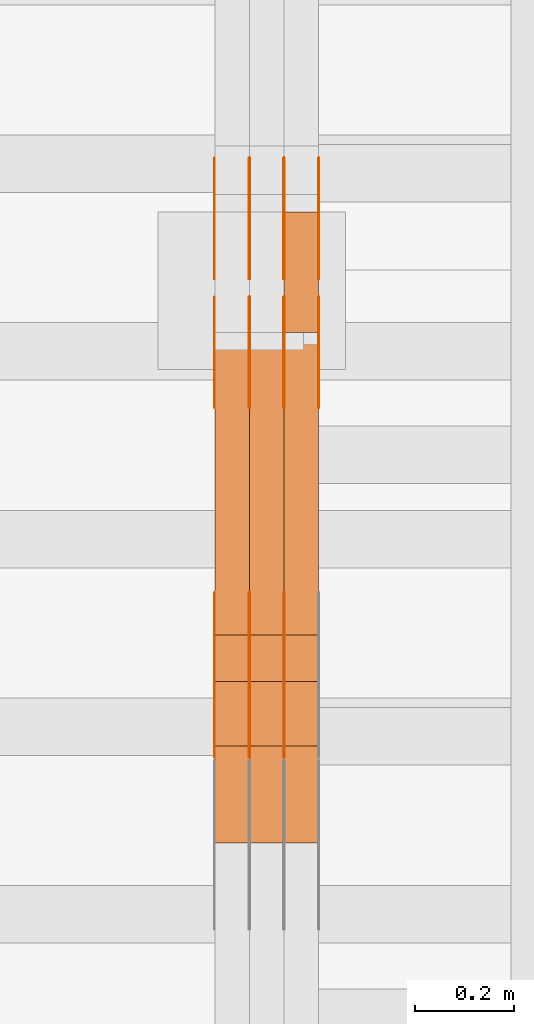
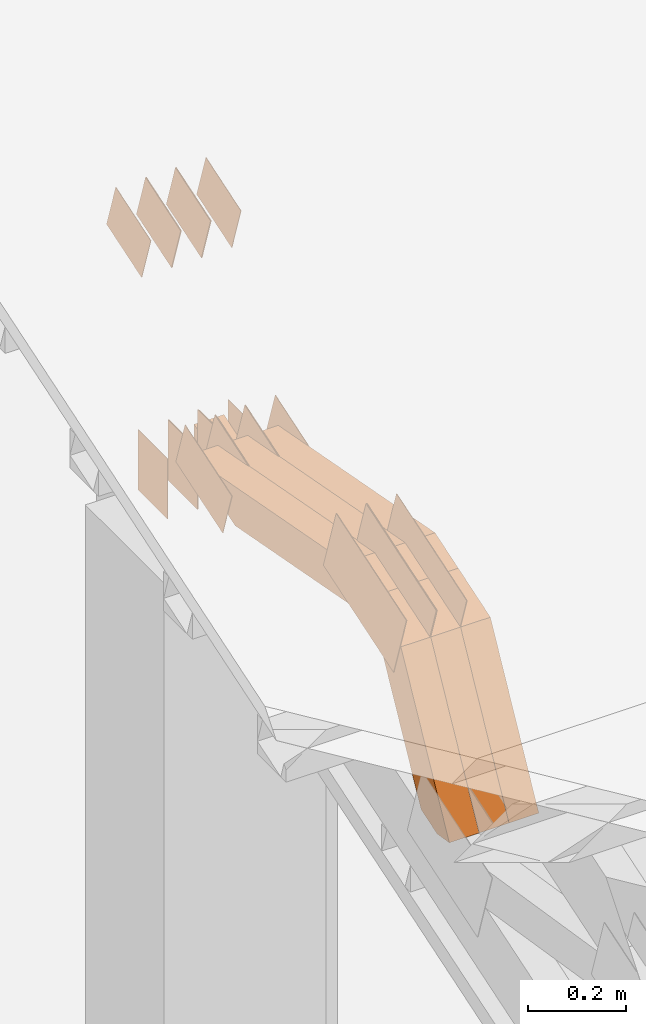
# One storey, part 74 of 385: 29 proxies.
"""IFC2X3 building model written with IfcOpenShell, lengths in millimetres."""

import ifcopenshell
import ifcopenshell.guid

model = None  # the IFC model being written
_history = None  # IfcOwnerHistory: only IFC2X3 demands one
_inside = {}  # id of a spatial element -> (the spatial element, [elements in it])
_under = {}  # id of a project, library or spatial element -> (it, [spatial elements below it])
_declared = {}  # id of a project -> (the project, [libraries it declares])
_typed = {}  # id of a type object -> (the type object, [elements of that type])
_made_of = {}  # id of a material, layer set ... -> (it, [elements and type objects made of it])


def new_model(schema):
    """Start an empty IFC model of exactly this schema.

    Asked for "IFC4X3", IfcOpenShell would pick the latest addendum, in which some entities
    have other attributes; the version numbers below select the first issue.
    IFC2X3 requires an IfcOwnerHistory on every rooted entity: one is made here for all.
    """
    global model, _history
    if schema == "IFC4X3":
        model = ifcopenshell.file(schema_version=(4, 3, 0, 0))
    else:
        model = ifcopenshell.file(schema=schema)
    _inside.clear()
    _under.clear()
    _declared.clear()
    _typed.clear()
    _made_of.clear()
    _history = None
    if model.schema == "IFC2X3":
        org = make("IfcOrganization", Name="unknown")
        user = make(
            "IfcPersonAndOrganization",
            ThePerson=make("IfcPerson", FamilyName="unknown"),
            TheOrganization=org,
        )
        app = make(
            "IfcApplication",
            ApplicationDeveloper=org,
            Version="unknown",
            ApplicationFullName="unknown",
            ApplicationIdentifier="unknown",
        )
        _history = make(
            "IfcOwnerHistory",
            OwningUser=user,
            OwningApplication=app,
            ChangeAction="ADDED",
            CreationDate=0,
        )
    return model


def make(cls, **values):
    """One entity of the class cls with the attributes given. An attribute that is None is left unset."""
    return model.create_entity(
        cls, **{name: value for name, value in values.items() if value is not None}
    )


def entity(cls, *values):
    """Any entity or typed value of the class cls, its attributes in the order of the schema. None: left unset."""
    e = model.create_entity(cls)
    for i, value in enumerate(values):
        if value is not None:
            e[i] = value
    return e


def rooted(cls, **values):
    """An entity with a GlobalId (a new one), such as an element, a storey or a relation."""
    return make(cls, GlobalId=ifcopenshell.guid.new(), OwnerHistory=_history, **values)


def si_unit(unit_type, name, prefix=None):
    """IfcSIUnit, for example si_unit("LENGTHUNIT", "METRE", prefix="MILLI")."""
    return make("IfcSIUnit", UnitType=unit_type, Prefix=prefix, Name=name)


def converted_unit(unit_type, name, factor, base, dimensions=None, offset=None):
    """IfcConversionBasedUnit, such as the inch: factor (a typed value) times the base unit."""
    return make(
        "IfcConversionBasedUnit"
        if offset is None
        else "IfcConversionBasedUnitWithOffset",
        ConversionOffset=offset,
        Dimensions=None
        if dimensions is None
        else entity("IfcDimensionalExponents", *dimensions),
        UnitType=unit_type,
        Name=name,
        ConversionFactor=make(
            "IfcMeasureWithUnit", ValueComponent=factor, UnitComponent=base
        ),
    )


def derived_unit(unit_type, elements):
    """IfcDerivedUnit: a product of units, each with its exponent."""
    return make(
        "IfcDerivedUnit",
        Elements=[
            make("IfcDerivedUnitElement", Unit=unit, Exponent=power)
            for unit, power in elements
        ],
        UnitType=unit_type,
    )


def assignment(units):
    """IfcUnitAssignment: the units of a project."""
    return None if units is None else make("IfcUnitAssignment", Units=units)


def point(xyz):
    """IfcCartesianPoint."""
    return None if xyz is None else make("IfcCartesianPoint", Coordinates=xyz)


def direction(xyz):
    """IfcDirection."""
    return None if xyz is None else make("IfcDirection", DirectionRatios=xyz)


def frame(location, z_axis=None, x_axis=None):
    """IfcAxis2Placement3D, a coordinate frame: its origin and axes. An axis left out is left unset."""
    return make(
        "IfcAxis2Placement3D",
        Location=point(location),
        Axis=direction(z_axis),
        RefDirection=direction(x_axis),
    )


def frame_2d(location, x_axis=None):
    """IfcAxis2Placement2D, a coordinate frame in the plane: its origin and x axis."""
    return make(
        "IfcAxis2Placement2D", Location=point(location), RefDirection=direction(x_axis)
    )


def origin():
    """The frame at (0, 0, 0) with its axes left unset."""
    return frame((0.0, 0.0, 0.0))


def place(relative_to, where):
    """IfcLocalPlacement: puts the frame where relative to a parent placement (None: the world)."""
    return make(
        "IfcLocalPlacement", PlacementRelTo=relative_to, RelativePlacement=where
    )


def context(
    kind, dimensions, precision=None, world=None, true_north=None, identifier=None
):
    """IfcGeometricRepresentationContext, for example the 3D "Model" context."""
    return make(
        "IfcGeometricRepresentationContext",
        ContextIdentifier=identifier,
        ContextType=kind,
        CoordinateSpaceDimension=dimensions,
        Precision=precision,
        WorldCoordinateSystem=world,
        TrueNorth=true_north,
    )


def subcontext(parent, identifier, kind, view, scale=None):
    """IfcGeometricRepresentationSubContext, for example "Body" below "Model"."""
    return make(
        "IfcGeometricRepresentationSubContext",
        ContextIdentifier=identifier,
        ContextType=kind,
        ParentContext=parent,
        TargetScale=scale,
        TargetView=view,
    )


def project(units=None, contexts=None):
    """IfcProject with its units and contexts."""
    return rooted(
        "IfcProject",
        Name="project",
        RepresentationContexts=contexts,
        UnitsInContext=assignment(units),
    )


def spatial(cls, under=None, at=None, **own):
    """A site, building, storey or space (cls), placed at a placement, below another one or the project."""
    s = rooted(cls, ObjectPlacement=at, **own)
    if under is not None:
        _under.setdefault(under.id(), (under, []))[1].append(s)
    return s


def polyline(points):
    """IfcPolyline through the points."""
    return make("IfcPolyline", Points=[point(p) for p in points])


def profile(cls, at=None, kind="AREA", **sizes):
    """A parametric profile (cls). Its sizes go by their IFC names, for example OverallWidth=200.0."""
    return make(cls, ProfileType=kind, Position=at, **sizes)


def rectangle(**sizes):
    """IfcRectangleProfileDef."""
    return profile("IfcRectangleProfileDef", **sizes)


def outline(outer, holes=None, kind="AREA"):
    """IfcArbitraryClosedProfileDef: a profile drawn as a closed curve; with holes, ...WithVoids."""
    if holes is None:
        return make("IfcArbitraryClosedProfileDef", ProfileType=kind, OuterCurve=outer)
    return make(
        "IfcArbitraryProfileDefWithVoids",
        ProfileType=kind,
        OuterCurve=outer,
        InnerCurves=holes,
    )


def extrude(swept, where, along, depth):
    """IfcExtrudedAreaSolid: the profile swept, set in the frame where, extruded along a direction by depth."""
    return make(
        "IfcExtrudedAreaSolid",
        SweptArea=swept,
        Position=where,
        ExtrudedDirection=direction(along),
        Depth=depth,
    )


def shape(context_of_items, identifier, shape_type, items):
    """IfcShapeRepresentation: the items that make up one representation, for example the "Body"."""
    return make(
        "IfcShapeRepresentation",
        ContextOfItems=context_of_items,
        RepresentationIdentifier=identifier,
        RepresentationType=shape_type,
        Items=items,
    )


def source(mapping_origin, context_of_items, identifier, shape_type, items):
    """IfcRepresentationMap: a shape defined once, which mapped items show again and again."""
    return make(
        "IfcRepresentationMap",
        MappingOrigin=mapping_origin,
        MappedRepresentation=shape(context_of_items, identifier, shape_type, items),
    )


def transform(
    local_origin,
    x_axis=None,
    y_axis=None,
    z_axis=None,
    scale=None,
    scale2=None,
    scale3=None,
    uniform=True,
):
    """IfcCartesianTransformationOperator3D, or its non-uniform kind. x_axis, y_axis, z_axis: its Axis1, 2, 3."""
    if uniform:
        return make(
            "IfcCartesianTransformationOperator3D",
            Axis1=direction(x_axis),
            Axis2=direction(y_axis),
            LocalOrigin=point(local_origin),
            Scale=scale,
            Axis3=direction(z_axis),
        )
    return make(
        "IfcCartesianTransformationOperator3DnonUniform",
        Axis1=direction(x_axis),
        Axis2=direction(y_axis),
        LocalOrigin=point(local_origin),
        Scale=scale,
        Axis3=direction(z_axis),
        Scale2=scale2,
        Scale3=scale3,
    )


def mapped(mapping_source, mapping_target):
    """IfcMappedItem: shows the shape of a source again, moved by a transform."""
    return make(
        "IfcMappedItem", MappingSource=mapping_source, MappingTarget=mapping_target
    )


def material(Name=None, Category=None):
    """IfcMaterial."""
    return make("IfcMaterial", Name=Name, Category=Category)


def made_of(thing, what):
    """Note that an element or type object is made of a material, layer set ...; save() writes the relation."""
    if what is not None:
        _made_of.setdefault(what.id(), (what, []))[1].append(thing)
    return thing


def type_object(cls, material=None, **own):
    """A type object (cls), such as IfcWallType, which elements share."""
    return made_of(rooted(cls, **own), material)


def type_shapes(of_type, sources):
    """Give a type object the sources (RepresentationMaps) that its elements show as mapped items."""
    of_type.RepresentationMaps = sources


def element(
    cls,
    number,
    at=None,
    inside=None,
    cuts=None,
    type_object=None,
    material=None,
    context=None,
    identifier="Body",
    shape_type=None,
    held_by="IfcProductDefinitionShape",
    body=None,
    shapes=None,
    **own,
):
    """One element of the class cls, such as IfcWall. Its Tag is "e" and its number.

    at: its placement. inside: the storey or other place that contains it. cuts: it is an
    opening in that element (IfcRelVoidsElement). A single representation is given by context,
    identifier, shape_type and body (its items); several are given by shapes. held_by: the class
    of the entity that holds the representations. save() writes the other relations.
    """
    e = rooted(cls, Tag="e%d" % number, ObjectPlacement=at, **own)
    if body is not None:
        shapes = [shape(context, identifier, shape_type, body)]
    if shapes is not None:
        e.Representation = make(held_by, Representations=shapes)
    if inside is not None:
        _inside.setdefault(inside.id(), (inside, []))[1].append(e)
    if cuts is not None:
        rooted(
            "IfcRelVoidsElement", RelatingBuildingElement=cuts, RelatedOpeningElement=e
        )
    if type_object is not None:
        _typed.setdefault(type_object.id(), (type_object, []))[1].append(e)
    return made_of(e, material)


def aggregate(whole, parts):
    """IfcRelAggregates: a whole, such as a stair, and the parts it consists of."""
    return rooted("IfcRelAggregates", RelatingObject=whole, RelatedObjects=parts)


def save(model, path):
    """Write the relations noted so far, then the file.

    IfcRelAggregates (storeys below a building ...), IfcRelContainedInSpatialStructure (elements
    in a storey), IfcRelDefinesByType, IfcRelAssociatesMaterial and IfcRelDeclares: one each for
    every whole, place, type object, material and project.
    """
    for whole, parts in _under.values():
        aggregate(whole, parts)
    for where, things in _inside.values():
        rooted(
            "IfcRelContainedInSpatialStructure",
            RelatedElements=things,
            RelatingStructure=where,
        )
    for kind, things in _typed.values():
        rooted("IfcRelDefinesByType", RelatedObjects=things, RelatingType=kind)
    for what, things in _made_of.values():
        rooted("IfcRelAssociatesMaterial", RelatedObjects=things, RelatingMaterial=what)
    for by, libraries in _declared.values():
        rooted("IfcRelDeclares", RelatingContext=by, RelatedDefinitions=libraries)
    model.write(path)


model = new_model("IFC2X3")

# Units and contexts
model_context = context("Model", 3, precision=0.01, world=origin(), true_north=direction((6.12303176911189e-17, 1.0)))
body_context = subcontext(model_context, "Body", "Model", "MODEL_VIEW")
ifc_project = project(units=[si_unit("LENGTHUNIT", "METRE", prefix="MILLI"), si_unit("AREAUNIT", "SQUARE_METRE"), si_unit("VOLUMEUNIT", "CUBIC_METRE"), converted_unit("PLANEANGLEUNIT", "DEGREE", entity("IfcRatioMeasure", 0.0174532925199433), si_unit("PLANEANGLEUNIT", "RADIAN"), dimensions=[0, 0, 0, 0, 0, 0, 0]), si_unit("MASSUNIT", "GRAM", prefix="KILO"), derived_unit("MASSDENSITYUNIT", [(si_unit("MASSUNIT", "GRAM", prefix="KILO"), 1), (si_unit("LENGTHUNIT", "METRE"), -3)]), si_unit("TIMEUNIT", "SECOND"), si_unit("FREQUENCYUNIT", "HERTZ"), si_unit("THERMODYNAMICTEMPERATUREUNIT", "DEGREE_CELSIUS"), derived_unit("THERMALTRANSMITTANCEUNIT", [(si_unit("MASSUNIT", "GRAM", prefix="KILO"), 1), (si_unit("THERMODYNAMICTEMPERATUREUNIT", "KELVIN"), -1), (si_unit("TIMEUNIT", "SECOND"), -3)]), derived_unit("VOLUMETRICFLOWRATEUNIT", [(si_unit("LENGTHUNIT", "METRE"), 3), (si_unit("TIMEUNIT", "SECOND"), -1)]), si_unit("ELECTRICCURRENTUNIT", "AMPERE"), si_unit("ELECTRICVOLTAGEUNIT", "VOLT"), si_unit("POWERUNIT", "WATT"), si_unit("FORCEUNIT", "NEWTON", prefix="KILO"), si_unit("ILLUMINANCEUNIT", "LUX"), si_unit("LUMINOUSFLUXUNIT", "LUMEN"), si_unit("LUMINOUSINTENSITYUNIT", "CANDELA"), derived_unit("USERDEFINED", [(si_unit("MASSUNIT", "GRAM", prefix="KILO"), -1), (si_unit("LENGTHUNIT", "METRE"), -2), (si_unit("TIMEUNIT", "SECOND"), 3), (si_unit("LUMINOUSFLUXUNIT", "LUMEN"), 1)]), derived_unit("LINEARVELOCITYUNIT", [(si_unit("LENGTHUNIT", "METRE"), 1), (si_unit("TIMEUNIT", "SECOND"), -1)]), si_unit("PRESSUREUNIT", "PASCAL"), derived_unit("USERDEFINED", [(si_unit("LENGTHUNIT", "METRE"), -2), (si_unit("MASSUNIT", "GRAM", prefix="KILO"), 1), (si_unit("TIMEUNIT", "SECOND"), -2)])], contexts=[model_context])

# Site, building, storey
site_placement = place(None, origin())
site = spatial("IfcSite", under=ifc_project, at=site_placement, CompositionType="ELEMENT")
building_placement = place(site_placement, origin())
building = spatial("IfcBuilding", under=site, at=building_placement, CompositionType="ELEMENT")
storey_placement = place(building_placement, origin())
storey = spatial("IfcBuildingStorey", under=building, at=storey_placement, Name="Default", CompositionType="ELEMENT", Elevation=0.0)

# Proxies
ifc_material_1 = material(Name="IfcSurfaceStyle #34928")
building_element_proxy_type_1 = type_object("IfcBuildingElementProxyType", PredefinedType="NOTDEFINED", material=ifc_material_1)
shared_shape_1 = source(origin(), body_context, "Body", "SweptSolid", [
    extrude(outline(polyline([(-99.9997874178038, -60.0000528641967), (99.9998102700997, -60.0000528641967), (99.9998251396068, 60.0000528641967), (-99.9998479919027, 60.0000528641967), (-99.9997874178038, -60.0000528641967)])), frame((99.9999918898597, 60.0000528641967, 0.0), z_axis=(0.0, 0.0, 1.0), x_axis=(-1.0, 0.0, 0.0)), (0.0, 0.0, 1.0), 1.3),
])
type_shapes(building_element_proxy_type_1, [shared_shape_1])
proxy_1_placement = place(building_placement, frame((386.299999999986, 11991.9568177725, 3072.52282247925), z_axis=(-1.0, 0.0, 0.0), x_axis=(0.0, 0.951056516295124, 0.309016994375039)))
element("IfcBuildingElementProxy", 1, at=proxy_1_placement, inside=storey, type_object=building_element_proxy_type_1, material=ifc_material_1, context=body_context, shape_type="MappedRepresentation", body=[
    mapped(shared_shape_1, transform((0.0, 0.0, 0.0), scale=1.0)),
])
ifc_material_2 = material(Name="IfcSurfaceStyle #34871")
building_element_proxy_type_2 = type_object("IfcBuildingElementProxyType", PredefinedType="NOTDEFINED", material=ifc_material_2)
shared_shape_2 = source(origin(), body_context, "Body", "SweptSolid", [
    extrude(outline(polyline([(-99.9997874178038, -60.0000528641967), (99.9998102700997, -60.0000528641967), (99.9998251396068, 60.0000528641967), (-99.9998479919027, 60.0000528641967), (-99.9997874178038, -60.0000528641967)])), frame((99.9999918898597, 60.0000528641967, 0.0), z_axis=(0.0, 0.0, 1.0), x_axis=(-1.0, 0.0, 0.0)), (0.0, 0.0, 1.0), 1.3),
])
type_shapes(building_element_proxy_type_2, [shared_shape_2])
proxy_2_placement = place(building_placement, frame((315.0, 11991.9568177725, 3072.52282247925), z_axis=(-1.0, 0.0, 0.0), x_axis=(0.0, 0.951056516295124, 0.309016994375039)))
element("IfcBuildingElementProxy", 2, at=proxy_2_placement, inside=storey, type_object=building_element_proxy_type_2, material=ifc_material_2, context=body_context, shape_type="MappedRepresentation", body=[
    mapped(shared_shape_2, transform((0.0, 0.0, 0.0), scale=1.0)),
])
ifc_material_3 = material(Name="IfcSurfaceStyle #34814")
building_element_proxy_type_3 = type_object("IfcBuildingElementProxyType", PredefinedType="NOTDEFINED", material=ifc_material_3)
shared_shape_3 = source(origin(), body_context, "Body", "SweptSolid", [
    extrude(outline(polyline([(-99.9997874178038, -60.0000528641967), (99.9998102700997, -60.0000528641967), (99.9998251396068, 60.0000528641967), (-99.9998479919027, 60.0000528641967), (-99.9997874178038, -60.0000528641967)])), frame((99.9999918898597, 60.0000528641967, 0.0), z_axis=(0.0, 0.0, 1.0), x_axis=(-1.0, 0.0, 0.0)), (0.0, 0.0, 1.0), 1.3),
])
type_shapes(building_element_proxy_type_3, [shared_shape_3])
proxy_3_placement = place(building_placement, frame((316.299999999986, 11991.9568177725, 3072.52282247925), z_axis=(-1.0, 0.0, 0.0), x_axis=(0.0, 0.951056516295124, 0.309016994375039)))
element("IfcBuildingElementProxy", 3, at=proxy_3_placement, inside=storey, type_object=building_element_proxy_type_3, material=ifc_material_3, context=body_context, shape_type="MappedRepresentation", body=[
    mapped(shared_shape_3, transform((0.0, 0.0, 0.0), scale=1.0)),
])
ifc_material_4 = material(Name="IfcSurfaceStyle #34757")
building_element_proxy_type_4 = type_object("IfcBuildingElementProxyType", PredefinedType="NOTDEFINED", material=ifc_material_4)
shared_shape_4 = source(origin(), body_context, "Body", "SweptSolid", [
    extrude(outline(polyline([(-99.9997874178038, -60.0000528641967), (99.9998102700997, -60.0000528641967), (99.9998251396068, 60.0000528641967), (-99.9998479919027, 60.0000528641967), (-99.9997874178038, -60.0000528641967)])), frame((99.9999918898597, 60.0000528641967, 0.0), z_axis=(0.0, 0.0, 1.0), x_axis=(-1.0, 0.0, 0.0)), (0.0, 0.0, 1.0), 1.29999999999998),
])
type_shapes(building_element_proxy_type_4, [shared_shape_4])
proxy_4_placement = place(building_placement, frame((245.0, 11991.9568177725, 3072.52282247925), z_axis=(-1.0, 0.0, 0.0), x_axis=(0.0, 0.951056516295124, 0.309016994375039)))
element("IfcBuildingElementProxy", 4, at=proxy_4_placement, inside=storey, type_object=building_element_proxy_type_4, material=ifc_material_4, context=body_context, shape_type="MappedRepresentation", body=[
    mapped(shared_shape_4, transform((0.0, 0.0, 0.0), scale=1.0)),
])
ifc_material_5 = material(Name="IfcSurfaceStyle #34700")
building_element_proxy_type_5 = type_object("IfcBuildingElementProxyType", PredefinedType="NOTDEFINED", material=ifc_material_5)
shared_shape_5 = source(origin(), body_context, "Body", "SweptSolid", [
    extrude(outline(polyline([(-99.9997874178038, -60.0000528641967), (99.9998102700997, -60.0000528641967), (99.9998251396068, 60.0000528641967), (-99.9998479919027, 60.0000528641967), (-99.9997874178038, -60.0000528641967)])), frame((99.9999918898597, 60.0000528641967, 0.0), z_axis=(0.0, 0.0, 1.0), x_axis=(-1.0, 0.0, 0.0)), (0.0, 0.0, 1.0), 1.29999999999998),
])
type_shapes(building_element_proxy_type_5, [shared_shape_5])
proxy_5_placement = place(building_placement, frame((246.299999999986, 11991.9568177725, 3072.52282247925), z_axis=(-1.0, 0.0, 0.0), x_axis=(0.0, 0.951056516295124, 0.309016994375039)))
element("IfcBuildingElementProxy", 5, at=proxy_5_placement, inside=storey, type_object=building_element_proxy_type_5, material=ifc_material_5, context=body_context, shape_type="MappedRepresentation", body=[
    mapped(shared_shape_5, transform((0.0, 0.0, 0.0), scale=1.0)),
])
ifc_material_6 = material(Name="IfcSurfaceStyle #34643")
building_element_proxy_type_6 = type_object("IfcBuildingElementProxyType", PredefinedType="NOTDEFINED", material=ifc_material_6)
shared_shape_6 = source(origin(), body_context, "Body", "SweptSolid", [
    extrude(outline(polyline([(-99.9997874178038, -60.0000528641967), (99.9998102700997, -60.0000528641967), (99.9998251396068, 60.0000528641967), (-99.9998479919027, 60.0000528641967), (-99.9997874178038, -60.0000528641967)])), frame((99.9999918898597, 60.0000528641967, 0.0), z_axis=(0.0, 0.0, 1.0), x_axis=(-1.0, 0.0, 0.0)), (0.0, 0.0, 1.0), 1.29999999999999),
])
type_shapes(building_element_proxy_type_6, [shared_shape_6])
proxy_6_placement = place(building_placement, frame((175.0, 11991.9568177725, 3072.52282247925), z_axis=(-1.0, 0.0, 0.0), x_axis=(0.0, 0.951056516295124, 0.309016994375039)))
element("IfcBuildingElementProxy", 6, at=proxy_6_placement, inside=storey, type_object=building_element_proxy_type_6, material=ifc_material_6, context=body_context, shape_type="MappedRepresentation", body=[
    mapped(shared_shape_6, transform((0.0, 0.0, 0.0), scale=1.0)),
])
ifc_material_7 = material(Name="IfcSurfaceStyle #34586")
building_element_proxy_type_7 = type_object("IfcBuildingElementProxyType", PredefinedType="NOTDEFINED", material=ifc_material_7)
shared_shape_7 = source(origin(), body_context, "Body", "SweptSolid", [
    extrude(rectangle(XDim=150.0, YDim=119.999999999985, at=frame_2d((-7.105427357601e-15, 0.0), x_axis=(1.0, 0.0))), frame((75.0, 60.0, 0.0), z_axis=(0.0, 0.0, 1.0), x_axis=(-1.0, 0.0, 0.0)), (0.0, 0.0, 1.0), 1.3),
])
type_shapes(building_element_proxy_type_7, [shared_shape_7])
proxy_7_placement = place(building_placement, frame((386.299999999986, 12372.95703125, 3007.04687500001), z_axis=(-1.0, 0.0, 0.0), x_axis=(0.0, 0.0, -1.0)))
element("IfcBuildingElementProxy", 7, at=proxy_7_placement, inside=storey, type_object=building_element_proxy_type_7, material=ifc_material_7, context=body_context, shape_type="MappedRepresentation", body=[
    mapped(shared_shape_7, transform((0.0, 0.0, 0.0), scale=1.0)),
])
ifc_material_8 = material(Name="IfcSurfaceStyle #34529")
building_element_proxy_type_8 = type_object("IfcBuildingElementProxyType", PredefinedType="NOTDEFINED", material=ifc_material_8)
shared_shape_8 = source(origin(), body_context, "Body", "SweptSolid", [
    extrude(rectangle(XDim=150.0, YDim=119.999999999985, at=frame_2d((-7.105427357601e-15, 0.0), x_axis=(1.0, 0.0))), frame((75.0, 60.0, 0.0), z_axis=(0.0, 0.0, 1.0), x_axis=(-1.0, 0.0, 0.0)), (0.0, 0.0, 1.0), 1.3),
])
type_shapes(building_element_proxy_type_8, [shared_shape_8])
proxy_8_placement = place(building_placement, frame((315.0, 12372.95703125, 3007.04687500001), z_axis=(-1.0, 0.0, 0.0), x_axis=(0.0, 0.0, -1.0)))
element("IfcBuildingElementProxy", 8, at=proxy_8_placement, inside=storey, type_object=building_element_proxy_type_8, material=ifc_material_8, context=body_context, shape_type="MappedRepresentation", body=[
    mapped(shared_shape_8, transform((0.0, 0.0, 0.0), scale=1.0)),
])
ifc_material_9 = material(Name="IfcSurfaceStyle #34472")
building_element_proxy_type_9 = type_object("IfcBuildingElementProxyType", PredefinedType="NOTDEFINED", material=ifc_material_9)
shared_shape_9 = source(origin(), body_context, "Body", "SweptSolid", [
    extrude(rectangle(XDim=150.0, YDim=119.999999999985, at=frame_2d((-7.105427357601e-15, 0.0), x_axis=(1.0, 0.0))), frame((75.0, 60.0, 0.0), z_axis=(0.0, 0.0, 1.0), x_axis=(-1.0, 0.0, 0.0)), (0.0, 0.0, 1.0), 1.3),
])
type_shapes(building_element_proxy_type_9, [shared_shape_9])
proxy_9_placement = place(building_placement, frame((316.299999999986, 12372.95703125, 3007.04687500001), z_axis=(-1.0, 0.0, 0.0), x_axis=(0.0, 0.0, -1.0)))
element("IfcBuildingElementProxy", 9, at=proxy_9_placement, inside=storey, type_object=building_element_proxy_type_9, material=ifc_material_9, context=body_context, shape_type="MappedRepresentation", body=[
    mapped(shared_shape_9, transform((0.0, 0.0, 0.0), scale=1.0)),
])
ifc_material_10 = material(Name="IfcSurfaceStyle #34415")
building_element_proxy_type_10 = type_object("IfcBuildingElementProxyType", PredefinedType="NOTDEFINED", material=ifc_material_10)
shared_shape_10 = source(origin(), body_context, "Body", "SweptSolid", [
    extrude(rectangle(XDim=150.0, YDim=119.999999999985, at=frame_2d((-7.105427357601e-15, 0.0), x_axis=(1.0, 0.0))), frame((75.0, 60.0, 0.0), z_axis=(0.0, 0.0, 1.0), x_axis=(-1.0, 0.0, 0.0)), (0.0, 0.0, 1.0), 1.29999999999999),
])
type_shapes(building_element_proxy_type_10, [shared_shape_10])
proxy_10_placement = place(building_placement, frame((245.0, 12372.95703125, 3007.04687500001), z_axis=(-1.0, 0.0, 0.0), x_axis=(0.0, 0.0, -1.0)))
element("IfcBuildingElementProxy", 10, at=proxy_10_placement, inside=storey, type_object=building_element_proxy_type_10, material=ifc_material_10, context=body_context, shape_type="MappedRepresentation", body=[
    mapped(shared_shape_10, transform((0.0, 0.0, 0.0), scale=1.0)),
])
ifc_material_11 = material(Name="IfcSurfaceStyle #34358")
building_element_proxy_type_11 = type_object("IfcBuildingElementProxyType", PredefinedType="NOTDEFINED", material=ifc_material_11)
shared_shape_11 = source(origin(), body_context, "Body", "SweptSolid", [
    extrude(rectangle(XDim=150.0, YDim=119.999999999985, at=frame_2d((-7.105427357601e-15, 0.0), x_axis=(1.0, 0.0))), frame((75.0, 60.0, 0.0), z_axis=(0.0, 0.0, 1.0), x_axis=(-1.0, 0.0, 0.0)), (0.0, 0.0, 1.0), 1.29999999999999),
])
type_shapes(building_element_proxy_type_11, [shared_shape_11])
proxy_11_placement = place(building_placement, frame((246.299999999986, 12372.95703125, 3007.04687500001), z_axis=(-1.0, 0.0, 0.0), x_axis=(0.0, 0.0, -1.0)))
element("IfcBuildingElementProxy", 11, at=proxy_11_placement, inside=storey, type_object=building_element_proxy_type_11, material=ifc_material_11, context=body_context, shape_type="MappedRepresentation", body=[
    mapped(shared_shape_11, transform((0.0, 0.0, 0.0), scale=1.0)),
])
ifc_material_12 = material(Name="IfcSurfaceStyle #34301")
building_element_proxy_type_12 = type_object("IfcBuildingElementProxyType", PredefinedType="NOTDEFINED", material=ifc_material_12)
shared_shape_12 = source(origin(), body_context, "Body", "SweptSolid", [
    extrude(rectangle(XDim=150.0, YDim=119.999999999985, at=frame_2d((-7.105427357601e-15, 0.0), x_axis=(1.0, 0.0))), frame((75.0, 60.0, 0.0), z_axis=(0.0, 0.0, 1.0), x_axis=(-1.0, 0.0, 0.0)), (0.0, 0.0, 1.0), 1.29999999999999),
])
type_shapes(building_element_proxy_type_12, [shared_shape_12])
proxy_12_placement = place(building_placement, frame((175.0, 12372.95703125, 3007.04687500001), z_axis=(-1.0, 0.0, 0.0), x_axis=(0.0, 0.0, -1.0)))
element("IfcBuildingElementProxy", 12, at=proxy_12_placement, inside=storey, type_object=building_element_proxy_type_12, material=ifc_material_12, context=body_context, shape_type="MappedRepresentation", body=[
    mapped(shared_shape_12, transform((0.0, 0.0, 0.0), scale=1.0)),
])
ifc_material_13 = material(Name="IfcSurfaceStyle #27404")
building_element_proxy_type_13 = type_object("IfcBuildingElementProxyType", PredefinedType="NOTDEFINED", material=ifc_material_13)
shared_shape_13 = source(origin(), body_context, "Body", "SweptSolid", [
    extrude(outline(polyline([(-74.9998754286244, -60.0000016373506), (74.9998605591063, -60.0000016373506), (74.9998754286244, 60.0000016373506), (-74.9998605591063, 60.0000016373506), (-74.9998754286244, -60.0000016373506)])), frame((74.9998754286244, 60.0000016373506, 0.0), z_axis=(0.0, 0.0, 1.0), x_axis=(-1.0, 0.0, 0.0)), (0.0, 0.0, 1.0), 1.3),
])
type_shapes(building_element_proxy_type_13, [shared_shape_13])
proxy_13_placement = place(building_placement, frame((386.299999999986, 12321.1620861463, 3506.17707344366), z_axis=(-1.0, 0.0, 0.0), x_axis=(0.0, 0.951056516295154, 0.309016994374948)))
element("IfcBuildingElementProxy", 13, at=proxy_13_placement, inside=storey, type_object=building_element_proxy_type_13, material=ifc_material_13, context=body_context, shape_type="MappedRepresentation", body=[
    mapped(shared_shape_13, transform((0.0, 0.0, 0.0), scale=1.0)),
])
ifc_material_14 = material(Name="IfcSurfaceStyle #27347")
building_element_proxy_type_14 = type_object("IfcBuildingElementProxyType", PredefinedType="NOTDEFINED", material=ifc_material_14)
shared_shape_14 = source(origin(), body_context, "Body", "SweptSolid", [
    extrude(outline(polyline([(-74.9998754286244, -60.0000016373506), (74.9998605591063, -60.0000016373506), (74.9998754286244, 60.0000016373506), (-74.9998605591063, 60.0000016373506), (-74.9998754286244, -60.0000016373506)])), frame((74.9998754286244, 60.0000016373506, 0.0), z_axis=(0.0, 0.0, 1.0), x_axis=(-1.0, 0.0, 0.0)), (0.0, 0.0, 1.0), 1.3),
])
type_shapes(building_element_proxy_type_14, [shared_shape_14])
proxy_14_placement = place(building_placement, frame((315.0, 12321.1620861463, 3506.17707344366), z_axis=(-1.0, 0.0, 0.0), x_axis=(0.0, 0.951056516295154, 0.309016994374948)))
element("IfcBuildingElementProxy", 14, at=proxy_14_placement, inside=storey, type_object=building_element_proxy_type_14, material=ifc_material_14, context=body_context, shape_type="MappedRepresentation", body=[
    mapped(shared_shape_14, transform((0.0, 0.0, 0.0), scale=1.0)),
])
ifc_material_15 = material(Name="IfcSurfaceStyle #27290")
building_element_proxy_type_15 = type_object("IfcBuildingElementProxyType", PredefinedType="NOTDEFINED", material=ifc_material_15)
shared_shape_15 = source(origin(), body_context, "Body", "SweptSolid", [
    extrude(outline(polyline([(-74.9998754286244, -60.0000016373506), (74.9998605591063, -60.0000016373506), (74.9998754286244, 60.0000016373506), (-74.9998605591063, 60.0000016373506), (-74.9998754286244, -60.0000016373506)])), frame((74.9998754286244, 60.0000016373506, 0.0), z_axis=(0.0, 0.0, 1.0), x_axis=(-1.0, 0.0, 0.0)), (0.0, 0.0, 1.0), 1.3),
])
type_shapes(building_element_proxy_type_15, [shared_shape_15])
proxy_15_placement = place(building_placement, frame((316.299999999986, 12321.1620861463, 3506.17707344366), z_axis=(-1.0, 0.0, 0.0), x_axis=(0.0, 0.951056516295154, 0.309016994374948)))
element("IfcBuildingElementProxy", 15, at=proxy_15_placement, inside=storey, type_object=building_element_proxy_type_15, material=ifc_material_15, context=body_context, shape_type="MappedRepresentation", body=[
    mapped(shared_shape_15, transform((0.0, 0.0, 0.0), scale=1.0)),
])
ifc_material_16 = material(Name="IfcSurfaceStyle #27233")
building_element_proxy_type_16 = type_object("IfcBuildingElementProxyType", PredefinedType="NOTDEFINED", material=ifc_material_16)
shared_shape_16 = source(origin(), body_context, "Body", "SweptSolid", [
    extrude(outline(polyline([(-74.9998754286244, -60.0000016373506), (74.9998605591063, -60.0000016373506), (74.9998754286244, 60.0000016373506), (-74.9998605591063, 60.0000016373506), (-74.9998754286244, -60.0000016373506)])), frame((74.9998754286244, 60.0000016373506, 0.0), z_axis=(0.0, 0.0, 1.0), x_axis=(-1.0, 0.0, 0.0)), (0.0, 0.0, 1.0), 1.29999999999999),
])
type_shapes(building_element_proxy_type_16, [shared_shape_16])
proxy_16_placement = place(building_placement, frame((245.0, 12321.1620861463, 3506.17707344366), z_axis=(-1.0, 0.0, 0.0), x_axis=(0.0, 0.951056516295154, 0.309016994374948)))
element("IfcBuildingElementProxy", 16, at=proxy_16_placement, inside=storey, type_object=building_element_proxy_type_16, material=ifc_material_16, context=body_context, shape_type="MappedRepresentation", body=[
    mapped(shared_shape_16, transform((0.0, 0.0, 0.0), scale=1.0)),
])
ifc_material_17 = material(Name="IfcSurfaceStyle #27176")
building_element_proxy_type_17 = type_object("IfcBuildingElementProxyType", PredefinedType="NOTDEFINED", material=ifc_material_17)
shared_shape_17 = source(origin(), body_context, "Body", "SweptSolid", [
    extrude(outline(polyline([(-74.9998754286244, -60.0000016373506), (74.9998605591063, -60.0000016373506), (74.9998754286244, 60.0000016373506), (-74.9998605591063, 60.0000016373506), (-74.9998754286244, -60.0000016373506)])), frame((74.9998754286244, 60.0000016373506, 0.0), z_axis=(0.0, 0.0, 1.0), x_axis=(-1.0, 0.0, 0.0)), (0.0, 0.0, 1.0), 1.29999999999999),
])
type_shapes(building_element_proxy_type_17, [shared_shape_17])
proxy_17_placement = place(building_placement, frame((246.299999999986, 12321.1620861463, 3506.17707344366), z_axis=(-1.0, 0.0, 0.0), x_axis=(0.0, 0.951056516295154, 0.309016994374948)))
element("IfcBuildingElementProxy", 17, at=proxy_17_placement, inside=storey, type_object=building_element_proxy_type_17, material=ifc_material_17, context=body_context, shape_type="MappedRepresentation", body=[
    mapped(shared_shape_17, transform((0.0, 0.0, 0.0), scale=1.0)),
])
ifc_material_18 = material(Name="IfcSurfaceStyle #27119")
building_element_proxy_type_18 = type_object("IfcBuildingElementProxyType", PredefinedType="NOTDEFINED", material=ifc_material_18)
shared_shape_18 = source(origin(), body_context, "Body", "SweptSolid", [
    extrude(outline(polyline([(-74.9998754286244, -60.0000016373506), (74.9998605591063, -60.0000016373506), (74.9998754286244, 60.0000016373506), (-74.9998605591063, 60.0000016373506), (-74.9998754286244, -60.0000016373506)])), frame((74.9998754286244, 60.0000016373506, 0.0), z_axis=(0.0, 0.0, 1.0), x_axis=(-1.0, 0.0, 0.0)), (0.0, 0.0, 1.0), 1.29999999999999),
])
type_shapes(building_element_proxy_type_18, [shared_shape_18])
proxy_18_placement = place(building_placement, frame((175.0, 12321.1620861463, 3506.17707344366), z_axis=(-1.0, 0.0, 0.0), x_axis=(0.0, 0.951056516295154, 0.309016994374948)))
element("IfcBuildingElementProxy", 18, at=proxy_18_placement, inside=storey, type_object=building_element_proxy_type_18, material=ifc_material_18, context=body_context, shape_type="MappedRepresentation", body=[
    mapped(shared_shape_18, transform((0.0, 0.0, 0.0), scale=1.0)),
])
ifc_material_19 = material(Name="IfcSurfaceStyle #26606")
building_element_proxy_type_19 = type_object("IfcBuildingElementProxyType", PredefinedType="NOTDEFINED", material=ifc_material_19)
shared_shape_19 = source(origin(), body_context, "Body", "SweptSolid", [
    extrude(outline(polyline([(-150.000273478628, -84.0002987844282), (149.999198496832, -84.0002987844282), (150.000273478627, 84.0002987844282), (-149.999198496831, 84.0002987844282), (-150.000273478628, -84.0002987844282)])), frame((150.000273478627, 84.0002987844282, 0.0), z_axis=(0.0, 0.0, 1.0), x_axis=(-1.0, 0.0, 0.0)), (0.0, 0.0, 1.0), 1.29999999999999),
])
type_shapes(building_element_proxy_type_19, [shared_shape_19])
proxy_19_placement = place(building_placement, frame((316.299999999986, 11283.0116722926, 3194.09682266857), z_axis=(-1.0, 0.0, 0.0), x_axis=(0.0, 0.951056516295154, 0.309016994374948)))
element("IfcBuildingElementProxy", 19, at=proxy_19_placement, inside=storey, type_object=building_element_proxy_type_19, material=ifc_material_19, context=body_context, shape_type="MappedRepresentation", body=[
    mapped(shared_shape_19, transform((0.0, 0.0, 0.0), scale=1.0)),
])
ifc_material_20 = material(Name="IfcSurfaceStyle #26549")
building_element_proxy_type_20 = type_object("IfcBuildingElementProxyType", PredefinedType="NOTDEFINED", material=ifc_material_20)
shared_shape_20 = source(origin(), body_context, "Body", "SweptSolid", [
    extrude(outline(polyline([(-150.000273478628, -84.0002987844282), (149.999198496832, -84.0002987844282), (150.000273478627, 84.0002987844282), (-149.999198496831, 84.0002987844282), (-150.000273478628, -84.0002987844282)])), frame((150.000273478627, 84.0002987844282, 0.0), z_axis=(0.0, 0.0, 1.0), x_axis=(-1.0, 0.0, 0.0)), (0.0, 0.0, 1.0), 1.29999999999998),
])
type_shapes(building_element_proxy_type_20, [shared_shape_20])
proxy_20_placement = place(building_placement, frame((245.0, 11283.0116722926, 3194.09682266857), z_axis=(-1.0, 0.0, 0.0), x_axis=(0.0, 0.951056516295154, 0.309016994374948)))
element("IfcBuildingElementProxy", 20, at=proxy_20_placement, inside=storey, type_object=building_element_proxy_type_20, material=ifc_material_20, context=body_context, shape_type="MappedRepresentation", body=[
    mapped(shared_shape_20, transform((0.0, 0.0, 0.0), scale=1.0)),
])
ifc_material_21 = material(Name="IfcSurfaceStyle #26492")
building_element_proxy_type_21 = type_object("IfcBuildingElementProxyType", PredefinedType="NOTDEFINED", material=ifc_material_21)
shared_shape_21 = source(origin(), body_context, "Body", "SweptSolid", [
    extrude(outline(polyline([(-150.000273478628, -84.0002987844282), (149.999198496832, -84.0002987844282), (150.000273478627, 84.0002987844282), (-149.999198496831, 84.0002987844282), (-150.000273478628, -84.0002987844282)])), frame((150.000273478627, 84.0002987844282, 0.0), z_axis=(0.0, 0.0, 1.0), x_axis=(-1.0, 0.0, 0.0)), (0.0, 0.0, 1.0), 1.29999999999998),
])
type_shapes(building_element_proxy_type_21, [shared_shape_21])
proxy_21_placement = place(building_placement, frame((246.299999999986, 11283.0116722926, 3194.09682266857), z_axis=(-1.0, 0.0, 0.0), x_axis=(0.0, 0.951056516295154, 0.309016994374948)))
element("IfcBuildingElementProxy", 21, at=proxy_21_placement, inside=storey, type_object=building_element_proxy_type_21, material=ifc_material_21, context=body_context, shape_type="MappedRepresentation", body=[
    mapped(shared_shape_21, transform((0.0, 0.0, 0.0), scale=1.0)),
])
ifc_material_22 = material(Name="IfcSurfaceStyle #26435")
building_element_proxy_type_22 = type_object("IfcBuildingElementProxyType", PredefinedType="NOTDEFINED", material=ifc_material_22)
shared_shape_22 = source(origin(), body_context, "Body", "SweptSolid", [
    extrude(outline(polyline([(-150.000273478628, -84.0002987844282), (149.999198496832, -84.0002987844282), (150.000273478627, 84.0002987844282), (-149.999198496831, 84.0002987844282), (-150.000273478628, -84.0002987844282)])), frame((150.000273478627, 84.0002987844282, 0.0), z_axis=(0.0, 0.0, 1.0), x_axis=(-1.0, 0.0, 0.0)), (0.0, 0.0, 1.0), 1.29999999999998),
])
type_shapes(building_element_proxy_type_22, [shared_shape_22])
proxy_22_placement = place(building_placement, frame((175.0, 11283.0116722926, 3194.09682266857), z_axis=(-1.0, 0.0, 0.0), x_axis=(0.0, 0.951056516295154, 0.309016994374948)))
element("IfcBuildingElementProxy", 22, at=proxy_22_placement, inside=storey, type_object=building_element_proxy_type_22, material=ifc_material_22, context=body_context, shape_type="MappedRepresentation", body=[
    mapped(shared_shape_22, transform((0.0, 0.0, 0.0), scale=1.0)),
])
ifc_material_23 = material(Name="IfcSurfaceStyle #18944")
building_element_proxy_type_23 = type_object("IfcBuildingElementProxyType", Name="T1-E1 18942", PredefinedType="NOTDEFINED", material=ifc_material_23)
shared_shape_23 = source(origin(), body_context, "Body", "SweptSolid", [
    extrude(outline(polyline([(-75.1378173828004, -122.500000000005), (35.3350830078246, -122.500000000005), (35.3350830078004, 122.500000000005), (4.46765136717545, 122.500000000005), (-75.1378173828004, -122.500000000005)])), frame((35.3350830078246, 122.500000104877, 0.0), z_axis=(0.0, 0.0, 1.0), x_axis=(-1.0, 0.0, 0.0)), (0.0, 0.0, 1.0), 70.0),
])
type_shapes(building_element_proxy_type_23, [shared_shape_23])
proxy_23_placement = place(building_placement, frame((385.0, 12145.0, 2849.54565429685), z_axis=(-1.0, 0.0, 0.0), x_axis=(0.0, 0.0, 1.0)))
element("IfcBuildingElementProxy", 23, at=proxy_23_placement, inside=storey, type_object=building_element_proxy_type_23, material=ifc_material_23, Name="T1-E1", context=body_context, shape_type="MappedRepresentation", body=[
    mapped(shared_shape_23, transform((0.0, 0.0, 0.0), scale=1.0)),
])
ifc_material_24 = material(Name="IfcSurfaceStyle #16424")
building_element_proxy_type_24 = type_object("IfcBuildingElementProxyType", Name="T1-W9 16422", PredefinedType="NOTDEFINED", material=ifc_material_24)
shared_shape_24 = source(origin(), body_context, "Body", "SweptSolid", [
    extrude(outline(polyline([(-287.457507623288, -47.5000268597988), (288.590479960635, -47.5000268597988), (273.55062971372, -2.33146189358546e-05), (186.625054999886, 47.5000385171083), (-461.308657050953, 47.5000385171083), (-287.457507623288, -47.5000268597988)])), frame((288.590945855618, 47.5000968036551, 0.0), z_axis=(0.0, 0.0, 1.0), x_axis=(-1.0, 0.0, 0.0)), (0.0, 0.0, 1.0), 70.0),
])
type_shapes(building_element_proxy_type_24, [shared_shape_24])
proxy_24_placement = place(building_placement, frame((385.0, 11432.1200855376, 3205.63308612017), z_axis=(-1.0, 0.0, 0.0), x_axis=(0.0, 0.982760503514031, -0.184883186722992)))
element("IfcBuildingElementProxy", 24, at=proxy_24_placement, inside=storey, type_object=building_element_proxy_type_24, material=ifc_material_24, Name="T1-W9", context=body_context, shape_type="MappedRepresentation", body=[
    mapped(shared_shape_24, transform((0.0, 0.0, 0.0), scale=1.0)),
])
ifc_material_25 = material(Name="IfcSurfaceStyle #16358")
building_element_proxy_type_25 = type_object("IfcBuildingElementProxyType", Name="T1-W9 16356", PredefinedType="NOTDEFINED", material=ifc_material_25)
shared_shape_25 = source(origin(), body_context, "Body", "SweptSolid", [
    extrude(outline(polyline([(-287.457507623288, -47.5000268597988), (288.590479960635, -47.5000268597988), (273.55062971372, -2.33146189358546e-05), (186.625054999886, 47.5000385171083), (-461.308657050953, 47.5000385171083), (-287.457507623288, -47.5000268597988)])), frame((288.590945855618, 47.5000968036551, 0.0), z_axis=(0.0, 0.0, 1.0), x_axis=(-1.0, 0.0, 0.0)), (0.0, 0.0, 1.0), 70.0),
])
type_shapes(building_element_proxy_type_25, [shared_shape_25])
proxy_25_placement = place(building_placement, frame((315.0, 11432.1200855376, 3205.63308612017), z_axis=(-1.0, 0.0, 0.0), x_axis=(0.0, 0.982760503514031, -0.184883186722992)))
element("IfcBuildingElementProxy", 25, at=proxy_25_placement, inside=storey, type_object=building_element_proxy_type_25, material=ifc_material_25, Name="T1-W9", context=body_context, shape_type="MappedRepresentation", body=[
    mapped(shared_shape_25, transform((0.0, 0.0, 0.0), scale=1.0)),
])
ifc_material_26 = material(Name="IfcSurfaceStyle #16292")
building_element_proxy_type_26 = type_object("IfcBuildingElementProxyType", Name="T1-W9 16290", PredefinedType="NOTDEFINED", material=ifc_material_26)
shared_shape_26 = source(origin(), body_context, "Body", "SweptSolid", [
    extrude(outline(polyline([(-287.457507623288, -47.5000268597988), (288.590479960635, -47.5000268597988), (273.55062971372, -2.33146189358546e-05), (186.625054999886, 47.5000385171083), (-461.308657050953, 47.5000385171083), (-287.457507623288, -47.5000268597988)])), frame((288.590945855618, 47.5000968036551, 0.0), z_axis=(0.0, 0.0, 1.0), x_axis=(-1.0, 0.0, 0.0)), (0.0, 0.0, 1.0), 70.0),
])
type_shapes(building_element_proxy_type_26, [shared_shape_26])
proxy_26_placement = place(building_placement, frame((245.0, 11432.1200855376, 3205.63308612017), z_axis=(-1.0, 0.0, 0.0), x_axis=(0.0, 0.982760503514031, -0.184883186722992)))
element("IfcBuildingElementProxy", 26, at=proxy_26_placement, inside=storey, type_object=building_element_proxy_type_26, material=ifc_material_26, Name="T1-W9", context=body_context, shape_type="MappedRepresentation", body=[
    mapped(shared_shape_26, transform((0.0, 0.0, 0.0), scale=1.0)),
])
ifc_material_27 = material(Name="IfcSurfaceStyle #16028")
building_element_proxy_type_27 = type_object("IfcBuildingElementProxyType", Name="T1-W32 16026", PredefinedType="NOTDEFINED", material=ifc_material_27)
shared_shape_27 = source(origin(), body_context, "Body", "SweptSolid", [
    extrude(outline(polyline([(-312.414547135921, -47.5000544873059), (136.677011757652, -47.5000544873059), (186.250996577889, 0.000369497452627243), (202.753116295831, 47.4998697385796), (-213.26657749545, 47.4998697385796), (-312.414547135921, -47.5000544873059)])), frame((202.753376481939, 47.5001296985553, 0.0), z_axis=(0.0, 0.0, 1.0), x_axis=(-1.0, 0.0, 0.0)), (0.0, 0.0, 1.0), 70.0),
])
type_shapes(building_element_proxy_type_27, [shared_shape_27])
proxy_27_placement = place(building_placement, frame((385.0, 11110.7808979007, 2747.18129017315), z_axis=(-1.0, 0.0, 0.0), x_axis=(0.0, 0.472919689385906, 0.881105537033526)))
element("IfcBuildingElementProxy", 27, at=proxy_27_placement, inside=storey, type_object=building_element_proxy_type_27, material=ifc_material_27, Name="T1-W32", context=body_context, shape_type="MappedRepresentation", body=[
    mapped(shared_shape_27, transform((0.0, 0.0, 0.0), scale=1.0)),
])
ifc_material_28 = material(Name="IfcSurfaceStyle #15962")
building_element_proxy_type_28 = type_object("IfcBuildingElementProxyType", Name="T1-W32 15960", PredefinedType="NOTDEFINED", material=ifc_material_28)
shared_shape_28 = source(origin(), body_context, "Body", "SweptSolid", [
    extrude(outline(polyline([(-312.414547135921, -47.5000544873059), (136.677011757652, -47.5000544873059), (186.250996577889, 0.000369497452627243), (202.753116295831, 47.4998697385796), (-213.26657749545, 47.4998697385796), (-312.414547135921, -47.5000544873059)])), frame((202.753376481939, 47.5001296985553, 0.0), z_axis=(0.0, 0.0, 1.0), x_axis=(-1.0, 0.0, 0.0)), (0.0, 0.0, 1.0), 70.0),
])
type_shapes(building_element_proxy_type_28, [shared_shape_28])
proxy_28_placement = place(building_placement, frame((315.0, 11110.7808979007, 2747.18129017315), z_axis=(-1.0, 0.0, 0.0), x_axis=(0.0, 0.472919689385906, 0.881105537033526)))
element("IfcBuildingElementProxy", 28, at=proxy_28_placement, inside=storey, type_object=building_element_proxy_type_28, material=ifc_material_28, Name="T1-W32", context=body_context, shape_type="MappedRepresentation", body=[
    mapped(shared_shape_28, transform((0.0, 0.0, 0.0), scale=1.0)),
])
ifc_material_29 = material(Name="IfcSurfaceStyle #15896")
building_element_proxy_type_29 = type_object("IfcBuildingElementProxyType", Name="T1-W32 15894", PredefinedType="NOTDEFINED", material=ifc_material_29)
shared_shape_29 = source(origin(), body_context, "Body", "SweptSolid", [
    extrude(outline(polyline([(-312.414547135921, -47.5000544873059), (136.677011757652, -47.5000544873059), (186.250996577889, 0.000369497452627243), (202.753116295831, 47.4998697385796), (-213.26657749545, 47.4998697385796), (-312.414547135921, -47.5000544873059)])), frame((202.753376481939, 47.5001296985553, 0.0), z_axis=(0.0, 0.0, 1.0), x_axis=(-1.0, 0.0, 0.0)), (0.0, 0.0, 1.0), 70.0),
])
type_shapes(building_element_proxy_type_29, [shared_shape_29])
proxy_29_placement = place(building_placement, frame((245.0, 11110.7808979007, 2747.18129017315), z_axis=(-1.0, 0.0, 0.0), x_axis=(0.0, 0.472919689385906, 0.881105537033526)))
element("IfcBuildingElementProxy", 29, at=proxy_29_placement, inside=storey, type_object=building_element_proxy_type_29, material=ifc_material_29, Name="T1-W32", context=body_context, shape_type="MappedRepresentation", body=[
    mapped(shared_shape_29, transform((0.0, 0.0, 0.0), scale=1.0)),
])

save(model, "model.ifc")
